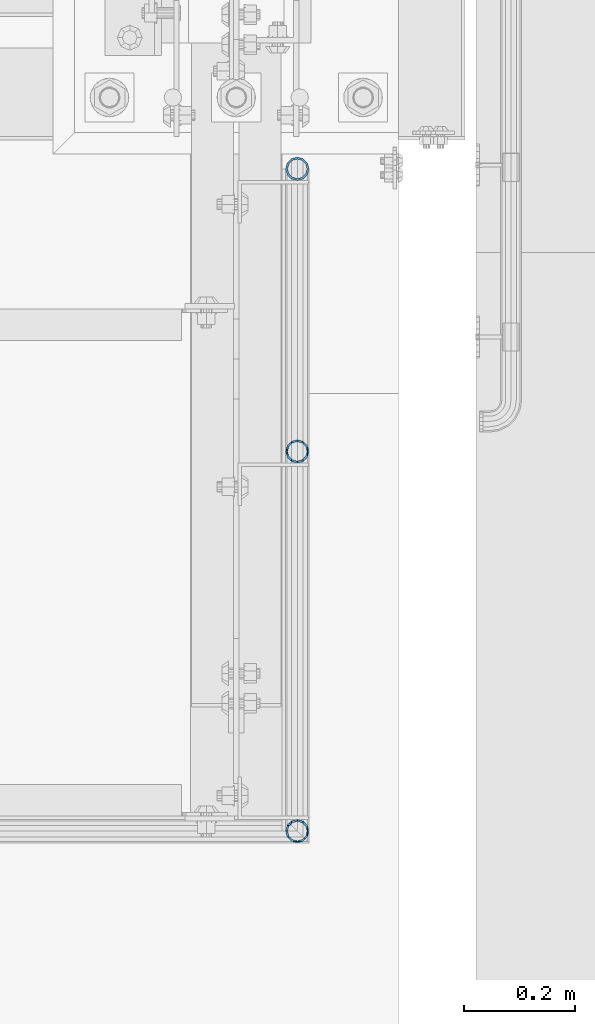
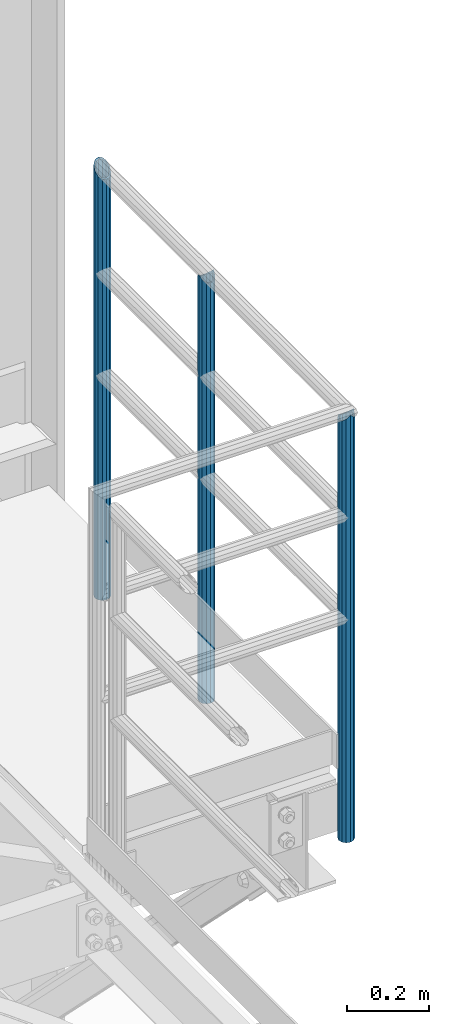
# One storey, part 651 of 1876: 3 columns, 1 element without a shape of its own.
"""IFC2X3 building model written with IfcOpenShell, lengths in millimetres."""

from ifc_helpers import new_model, si_unit, frame, origin_with_axes, place, context, subcontext, project, spatial, faceted_brep, material, type_object, element, aggregate, save


model = new_model("IFC2X3")

# Units and contexts
model_context = context("Model", 3, precision=1e-05, world=origin_with_axes())
body_context = subcontext(model_context, "Body", "Model", "MODEL_VIEW")
ifc_project = project(units=[si_unit("LENGTHUNIT", "METRE", prefix="MILLI"), si_unit("AREAUNIT", "SQUARE_METRE"), si_unit("VOLUMEUNIT", "CUBIC_METRE"), si_unit("MASSUNIT", "GRAM", prefix="KILO"), si_unit("TIMEUNIT", "SECOND"), si_unit("PLANEANGLEUNIT", "RADIAN"), si_unit("SOLIDANGLEUNIT", "STERADIAN"), si_unit("THERMODYNAMICTEMPERATUREUNIT", "DEGREE_CELSIUS"), si_unit("LUMINOUSINTENSITYUNIT", "LUMEN")], contexts=[model_context])

# Site, building, storey
site_placement = place(None, origin_with_axes())
site = spatial("IfcSite", under=ifc_project, at=site_placement, CompositionType="ELEMENT")
building_placement = place(site_placement, origin_with_axes())
building = spatial("IfcBuilding", under=site, at=building_placement, Name="Undefined", CompositionType="ELEMENT")
storey_placement = place(building_placement, origin_with_axes())
storey = spatial("IfcBuildingStorey", under=building, at=storey_placement, Name="Undefined", CompositionType="ELEMENT", Elevation=0.0)

# Assembly, columns
assembly_placement = place(storey_placement, origin_with_axes())
assembly = element("IfcElementAssembly", 1, at=assembly_placement, inside=storey, Name="HANDRAIL", AssemblyPlace="NOTDEFINED", PredefinedType="RIGID_FRAME")
ifc_material = material()
column_type = type_object("IfcColumnType", Name="PIPE1-1/4STD", PredefinedType="NOTDEFINED")
column_1_placement = place(assembly_placement, frame((7729.98590258003, -7978.68460156251, 7813.675), z_axis=(0.0, 1.0, 0.0), x_axis=(0.0, 0.0, 1.0)))
column_1 = element("IfcColumn", 2, at=column_1_placement, type_object=column_type, material=ifc_material, Name="POST", ObjectType="PIPE1-1/4STD", context=body_context, shape_type="Brep", body=[
    faceted_brep([(1258.09245243742, -10.5410000000002, 18.2575475625836), (1258.09245243742, -10.5449950422453, 13.395966184481), (1257.61496824169, -8.76299999999992, 15.1779612267264), (1255.268, 0.0, 17.5259999999998), (1255.268, 0.0, 21.0820000000003), (1257.61710930486, 8.76299999999992, 15.1779612267264), (1258.09245243742, 10.5370049566973, 13.4039562700291), (1258.09245243742, 10.5410000000002, 18.2575475625836), (1276.35, 21.0820000000003, 0.0), (1265.809, 18.2575475625836, 10.5410000000002), (1265.809, 18.2575475625836, -10.5410000000002), (1262.7334080928, 15.1779612267264, 8.76299999999992), (1265.0814457055, 17.5259999999998, 0.0), (1262.73340577165, 15.1779612267264, -8.76299999999992), (1258.09245243742, 10.5370085071409, -13.4039527195855), (1258.09245243742, 10.5410000000002, -18.2575475625836), (1257.61710822761, 8.76299999999992, -15.1779612267264), (1255.268, 0.0, -17.5259999999998), (1255.268, 0.0, -21.0820000000003), (1258.09245243742, -10.5449914939172, -13.3959697328091), (1258.09245243742, -10.5410000000002, -18.2575475625836), (1257.61496931894, -8.76299999999992, -15.1779612267264), (1276.35, -21.0859932680814, -5.29325916431844e-10), (1265.809, -18.2575475625836, -10.5410000000002), (1265.809, -18.2575475625836, 10.5410000000002), (1262.72542155664, -15.1779612267264, -8.76299999999992), (1265.07345916934, -17.5259999999998, 0.0), (1262.72541923549, -15.1779612267264, 8.76299999999992), (0.0, -18.2575475625836, -10.5409999999993), (0.0, -10.5410000000002, -18.2575475625836), (-4.28826751885936e-09, 0.0, -21.0820000000003), (0.0, 10.5410000000002, -18.2575475625836), (0.0, 18.2575475625836, -10.5409999999993), (9.09494701772928e-13, 21.0820000000003, 0.0), (0.0, 18.2575475625836, 10.5409999999993), (0.0, 10.5410000000002, 18.2575475625836), (0.0, 0.0, 21.0820000000003), (0.0, -10.5410000000002, 18.2575475625836), (0.0, -18.2575475625836, 10.5409999999993), (9.09494701772928e-13, -21.0820000000003, 0.0), (0.0, -15.1779612267264, -8.76300000000083), (0.0, -8.76299999999992, -15.1779612267255), (0.0, 0.0, -17.5259999999998), (0.0, 8.76299999999992, -15.1779612267255), (0.0, 15.1779612267264, -8.76300000000083), (0.0, 17.5259999999998, 0.0), (0.0, 15.1779612267264, 8.76300000000083), (0.0, 8.76299999999992, 15.1779612267255), (0.0, 0.0, 17.5259999999998), (0.0, -8.76299999999992, 15.1779612267255), (0.0, -15.1779612267264, 8.76300000000083), (0.0, -17.5259999999998, 0.0)], [[[0, 1, 2, 3, 4]], [[4, 3, 5, 6, 7]], [[8, 9, 10]], [[7, 6, 11, 12, 13, 14, 15, 10, 9]], [[16, 17, 18, 15, 14]], [[19, 20, 18, 17, 21]], [[22, 23, 24]], [[24, 23, 20, 19, 25, 26, 27, 1, 0]], [[28, 29, 20, 23]], [[29, 30, 18, 20]], [[30, 31, 15, 18]], [[31, 32, 10, 15]], [[32, 33, 8, 10]], [[33, 34, 9, 8]], [[34, 35, 7, 9]], [[35, 36, 4, 7]], [[36, 37, 0, 4]], [[37, 38, 24, 0]], [[38, 39, 22, 24]], [[39, 28, 23, 22]], [[38, 37, 36, 35, 34, 33, 32, 31, 30, 29, 28, 39], [40, 41, 42, 43, 44, 45, 46, 47, 48, 49, 50, 51]], [[40, 51, 26, 25]], [[21, 41, 40, 25, 19]], [[42, 41, 21, 17]], [[43, 42, 17, 16]], [[44, 43, 16, 14, 13]], [[45, 44, 13, 12]], [[46, 45, 12, 11]], [[5, 47, 46, 11, 6]], [[48, 47, 5, 3]], [[49, 48, 3, 2]], [[50, 49, 2, 1, 27]], [[51, 50, 27, 26]]]),
])
column_2_placement = place(assembly_placement, frame((7729.982, -7469.18749923706, 7813.675), z_axis=(0.0, 1.0, 0.0), x_axis=(0.0, 0.0, 1.0)))
column_2 = element("IfcColumn", 3, at=column_2_placement, type_object=column_type, material=ifc_material, Name="POST", ObjectType="PIPE1-1/4STD", context=body_context, shape_type="Brep", body=[
    faceted_brep([(0.0, -17.5259999999998, 0.0), (0.0, -15.1779612267264, 8.76300000000083), (1285.11300200349, -15.1779612267264, 8.76299999999992), (1276.35000231344, -17.5259999999998, 0.0), (0.0, -8.76299999999992, 15.1779612267255), (1291.52796238344, -8.76299999999992, 15.1779612267264), (0.0, 0.0, 17.5259999999998), (1293.876, 0.0, 17.5259999999998), (0.0, 8.76299999999992, 15.1779612267255), (1291.52796007001, 8.76299999999992, 15.1779612267264), (0.0, 15.1779612267264, 8.76300000000083), (1285.11299799651, 15.1779612267264, 8.76299999999992), (0.0, 17.5259999999998, 0.0), (1276.34999768657, 17.5259999999998, 0.0), (0.0, 15.1779612267264, -8.76300000000083), (1267.58699799651, 15.1779612267264, -8.76299999999992), (0.0, 8.76299999999992, -15.1779612267255), (1261.17203761656, 8.76299999999992, -15.1779612267264), (0.0, 0.0, -17.5259999999998), (1258.824, 0.0, -17.5259999999998), (0.0, -8.76299999999992, -15.1779612267255), (1261.17203992999, -8.76299999999992, -15.1779612267264), (0.0, -15.1779612267264, -8.76300000000083), (1267.58700200349, -15.1779612267264, -8.76299999999992), (9.09494701772928e-13, -21.0820000000003, 0.0), (0.0, -18.2575475625836, -10.5409999999993), (1265.809, -18.2575475625836, -10.5410000000002), (1276.35000278283, -21.0820000000003, 0.0), (0.0, -10.5410000000002, -18.2575475625836), (1258.09245243742, -10.5410000000002, -18.2575475625836), (-4.28826751885936e-09, 0.0, -21.0820000000003), (1255.268, 0.0, -21.0820000000003), (0.0, 10.5410000000002, -18.2575475625836), (1258.09245243742, 10.5410000000002, -18.2575475625836), (0.0, 18.2575475625836, -10.5409999999993), (1265.809, 18.2575475625836, -10.5410000000002), (9.09494701772928e-13, 21.0820000000003, 0.0), (1276.35, 21.0820000000003, 0.0), (0.0, 18.2575475625836, 10.5409999999993), (1286.89099759001, 18.2575475625836, 10.5410000000002), (0.0, 10.5410000000002, 18.2575475625836), (1294.60754617117, 10.5410000000002, 18.2575475625836), (0.0, 0.0, 21.0820000000003), (1297.432, 0.0, 21.0820000000003), (0.0, -10.5410000000002, 18.2575475625836), (1294.607548954, -10.5410000000002, 18.2575475625836), (0.0, -18.2575475625836, 10.5409999999993), (1286.89100241, -18.2575475625836, 10.5410000000002)], [[[0, 1, 2, 3]], [[1, 4, 5, 2]], [[4, 6, 7, 5]], [[6, 8, 9, 7]], [[8, 10, 11, 9]], [[10, 12, 13, 11]], [[12, 14, 15, 13]], [[14, 16, 17, 15]], [[16, 18, 19, 17]], [[18, 20, 21, 19]], [[20, 22, 23, 21]], [[22, 0, 3, 23]], [[24, 25, 26, 27]], [[25, 28, 29, 26]], [[28, 30, 31, 29]], [[30, 32, 33, 31]], [[32, 34, 35, 33]], [[34, 36, 37, 35]], [[36, 38, 39, 37]], [[38, 40, 41, 39]], [[40, 42, 43, 41]], [[42, 44, 45, 43]], [[44, 46, 47, 45]], [[46, 24, 27, 47]], [[29, 31, 33, 35, 37, 39, 41, 43, 45, 47, 27, 26], [5, 7, 9, 11, 13, 15, 17, 19, 21, 23, 3, 2]], [[46, 44, 42, 40, 38, 36, 34, 32, 30, 28, 25, 24], [22, 20, 18, 16, 14, 12, 10, 8, 6, 4, 1, 0]]]),
])
column_3_placement = place(assembly_placement, frame((7729.982, -8663.432, 7813.675), z_axis=(0.0, 1.0, 0.0), x_axis=(0.0, 0.0, 1.0)))
column_3 = element("IfcColumn", 4, at=column_3_placement, type_object=column_type, material=ifc_material, Name="POST", ObjectType="PIPE1-1/4STD", context=body_context, shape_type="Brep", body=[
    faceted_brep([(1276.35, 0.0, -21.0820000000003), (1265.809, 10.5410000000002, -18.2575475625836), (1265.809, -10.5410000000002, -18.2575475625836), (1261.95070660152, 14.399256071144, -14.3992914914397), (1259.52191359443, 11.9704627423807, -11.9704984843447), (1262.72937633681, 8.76299999999992, -15.1779612267255), (1265.07741511008, 0.0, -17.5259999999998), (1262.72937633681, -8.76299999999992, -15.1779612267255), (1258.09245243742, -13.3999238993902, -10.5410373273353), (1258.09245243742, -18.2575475625836, -10.5409999999993), (1257.61602877145, -15.1779612267264, -8.76300000000083), (1255.268, -17.5259999999998, 0.0), (1255.268, -21.0820000000003, 0.0), (1257.61604877511, -15.1779612267264, 8.76300000000083), (1258.09245243742, -13.3999985540622, 10.540962672665), (1258.09245243742, -18.2575475625836, 10.5409999999993), (1259.52195092176, -11.9705000697177, 11.9704611570087), (1261.95074392886, -14.3992933984809, 14.3992541641019), (1258.09245243742, -10.5410017746963, 13.3999594520301), (1258.09245243742, -10.5410000000002, 18.2575475625836), (1257.61603823465, -8.76299999999992, 15.1779612267255), (1255.268, 0.0, 17.5259999999998), (1255.268, 0.0, 21.0820000000003), (1257.6160393119, 8.76299999999992, 15.1779612267255), (1258.09245243742, 10.5409982253032, 13.3999630014223), (1258.09245243742, 10.5410000000002, 18.2575475625836), (1276.35, 21.0820000000003, 0.0), (1265.809, 18.2575475625836, 10.5410000000002), (1265.809, 18.2575475625836, -10.5410000000002), (1262.72941482472, 15.1779612267264, 8.76300000000083), (1265.07745243742, 17.5259999999998, 0.0), (1262.72941250358, 15.1779612267264, -8.76300000000083), (0.0, -18.2575475625836, -10.5409999999993), (0.0, -10.5410000000002, -18.2575475625836), (-4.28826751885936e-09, 0.0, -21.0820000000003), (0.0, 10.5410000000002, -18.2575475625836), (0.0, 18.2575475625836, -10.5409999999993), (9.09494701772928e-13, 21.0820000000003, 0.0), (0.0, -18.2575475625836, 10.5409999999993), (9.09494701772928e-13, -21.0820000000003, 0.0), (0.0, -10.5410000000002, 18.2575475625836), (0.0, 0.0, 21.0820000000003), (0.0, 10.5410000000002, 18.2575475625836), (0.0, 18.2575475625836, 10.5409999999993), (0.0, -15.1779612267264, -8.76300000000083), (0.0, -8.76299999999992, -15.1779612267255), (0.0, 0.0, -17.5259999999998), (0.0, 8.76299999999992, -15.1779612267255), (0.0, 15.1779612267264, -8.76300000000083), (0.0, 17.5259999999998, 0.0), (0.0, 15.1779612267264, 8.76300000000083), (0.0, 8.76299999999992, 15.1779612267255), (0.0, 0.0, 17.5259999999998), (0.0, -8.76299999999992, 15.1779612267255), (0.0, -15.1779612267264, 8.76300000000083), (0.0, -17.5259999999998, 0.0)], [[[0, 1, 2]], [[2, 1, 3, 4, 5, 6, 7, 8, 9]], [[9, 8, 10, 11, 12]], [[12, 11, 13, 14, 15]], [[15, 14, 16, 17]], [[17, 16, 18, 19]], [[19, 18, 20, 21, 22]], [[22, 21, 23, 24, 25]], [[26, 27, 28]], [[25, 24, 29, 30, 31, 4, 3, 28, 27]], [[32, 33, 2, 9]], [[33, 34, 0, 2]], [[34, 35, 1, 0]], [[1, 35, 36, 28, 3]], [[36, 37, 26, 28]], [[38, 39, 12, 15]], [[40, 38, 15, 17, 19]], [[41, 40, 19, 22]], [[42, 41, 22, 25]], [[43, 42, 25, 27]], [[37, 43, 27, 26]], [[39, 32, 9, 12]], [[38, 40, 41, 42, 43, 37, 36, 35, 34, 33, 32, 39], [44, 45, 46, 47, 48, 49, 50, 51, 52, 53, 54, 55]], [[50, 49, 30, 29]], [[23, 51, 50, 29, 24]], [[52, 51, 23, 21]], [[53, 52, 21, 20]], [[13, 54, 53, 20, 18, 16, 14]], [[55, 54, 13, 11]], [[44, 55, 11, 10]], [[45, 44, 10, 8, 7]], [[46, 45, 7, 6]], [[47, 46, 6, 5]], [[48, 47, 5, 4, 31]], [[49, 48, 31, 30]]]),
])
aggregate(assembly, [column_1, column_2, column_3])

save(model, "model.ifc")
